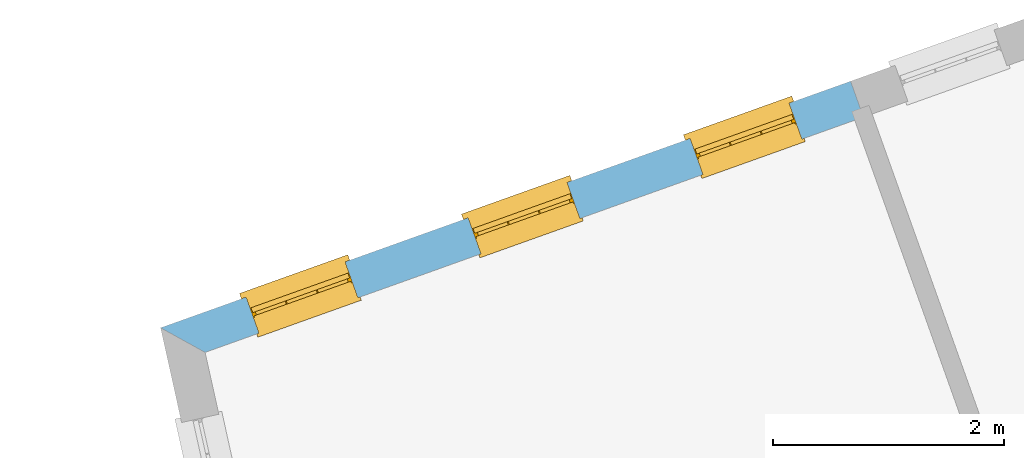
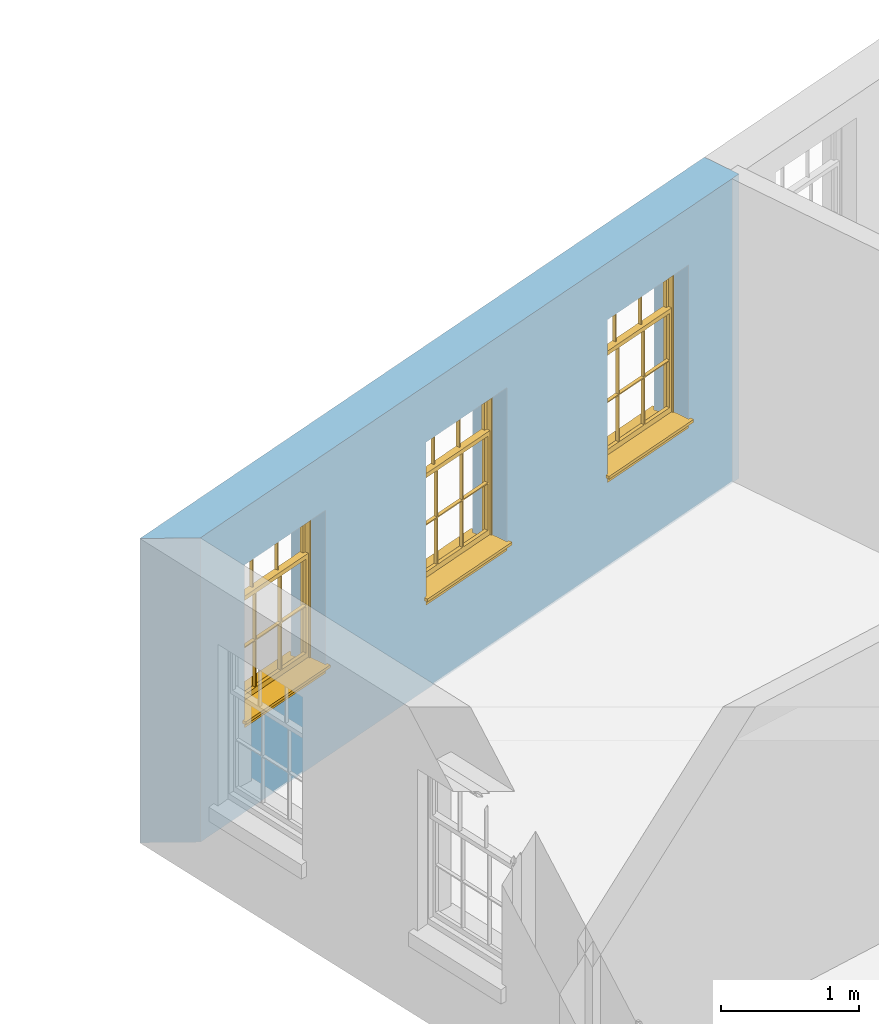
# One storey, part 4 of 11: 3 windows, 3 openings, plus 1 element that does not belong to this part.
"""IFC2X3 building model written with IfcOpenShell, lengths in metres."""

import ifcopenshell
import ifcopenshell.guid

model = None  # the IFC model being written
_history = None  # IfcOwnerHistory: only IFC2X3 demands one
_inside = {}  # id of a spatial element -> (the spatial element, [elements in it])
_under = {}  # id of a project, library or spatial element -> (it, [spatial elements below it])
_declared = {}  # id of a project -> (the project, [libraries it declares])
_typed = {}  # id of a type object -> (the type object, [elements of that type])
_made_of = {}  # id of a material, layer set ... -> (it, [elements and type objects made of it])


def new_model(schema):
    """Start an empty IFC model of exactly this schema.

    Asked for "IFC4X3", IfcOpenShell would pick the latest addendum, in which some entities
    have other attributes; the version numbers below select the first issue.
    IFC2X3 requires an IfcOwnerHistory on every rooted entity: one is made here for all.
    """
    global model, _history
    if schema == "IFC4X3":
        model = ifcopenshell.file(schema_version=(4, 3, 0, 0))
    else:
        model = ifcopenshell.file(schema=schema)
    _inside.clear()
    _under.clear()
    _declared.clear()
    _typed.clear()
    _made_of.clear()
    _history = None
    if model.schema == "IFC2X3":
        org = make("IfcOrganization", Name="unknown")
        user = make(
            "IfcPersonAndOrganization",
            ThePerson=make("IfcPerson", FamilyName="unknown"),
            TheOrganization=org,
        )
        app = make(
            "IfcApplication",
            ApplicationDeveloper=org,
            Version="unknown",
            ApplicationFullName="unknown",
            ApplicationIdentifier="unknown",
        )
        _history = make(
            "IfcOwnerHistory",
            OwningUser=user,
            OwningApplication=app,
            ChangeAction="ADDED",
            CreationDate=0,
        )
    return model


def make(cls, **values):
    """One entity of the class cls with the attributes given. An attribute that is None is left unset."""
    return model.create_entity(
        cls, **{name: value for name, value in values.items() if value is not None}
    )


def rooted(cls, **values):
    """An entity with a GlobalId (a new one), such as an element, a storey or a relation."""
    return make(cls, GlobalId=ifcopenshell.guid.new(), OwnerHistory=_history, **values)


def si_unit(unit_type, name, prefix=None):
    """IfcSIUnit, for example si_unit("LENGTHUNIT", "METRE", prefix="MILLI")."""
    return make("IfcSIUnit", UnitType=unit_type, Prefix=prefix, Name=name)


def assignment(units):
    """IfcUnitAssignment: the units of a project."""
    return None if units is None else make("IfcUnitAssignment", Units=units)


def point(xyz):
    """IfcCartesianPoint."""
    return None if xyz is None else make("IfcCartesianPoint", Coordinates=xyz)


def direction(xyz):
    """IfcDirection."""
    return None if xyz is None else make("IfcDirection", DirectionRatios=xyz)


def frame(location, z_axis=None, x_axis=None):
    """IfcAxis2Placement3D, a coordinate frame: its origin and axes. An axis left out is left unset."""
    return make(
        "IfcAxis2Placement3D",
        Location=point(location),
        Axis=direction(z_axis),
        RefDirection=direction(x_axis),
    )


def origin():
    """The frame at (0, 0, 0) with its axes left unset."""
    return frame((0.0, 0.0, 0.0))


def place(relative_to, where):
    """IfcLocalPlacement: puts the frame where relative to a parent placement (None: the world)."""
    return make(
        "IfcLocalPlacement", PlacementRelTo=relative_to, RelativePlacement=where
    )


def context(
    kind, dimensions, precision=None, world=None, true_north=None, identifier=None
):
    """IfcGeometricRepresentationContext, for example the 3D "Model" context."""
    return make(
        "IfcGeometricRepresentationContext",
        ContextIdentifier=identifier,
        ContextType=kind,
        CoordinateSpaceDimension=dimensions,
        Precision=precision,
        WorldCoordinateSystem=world,
        TrueNorth=true_north,
    )


def subcontext(parent, identifier, kind, view, scale=None):
    """IfcGeometricRepresentationSubContext, for example "Body" below "Model"."""
    return make(
        "IfcGeometricRepresentationSubContext",
        ContextIdentifier=identifier,
        ContextType=kind,
        ParentContext=parent,
        TargetScale=scale,
        TargetView=view,
    )


def project(units=None, contexts=None):
    """IfcProject with its units and contexts."""
    return rooted(
        "IfcProject",
        Name="project",
        RepresentationContexts=contexts,
        UnitsInContext=assignment(units),
    )


def spatial(cls, under=None, at=None, **own):
    """A site, building, storey or space (cls), placed at a placement, below another one or the project."""
    s = rooted(cls, ObjectPlacement=at, **own)
    if under is not None:
        _under.setdefault(under.id(), (under, []))[1].append(s)
    return s


def polyline(points):
    """IfcPolyline through the points."""
    return make("IfcPolyline", Points=[point(p) for p in points])


def outline(outer, holes=None, kind="AREA"):
    """IfcArbitraryClosedProfileDef: a profile drawn as a closed curve; with holes, ...WithVoids."""
    if holes is None:
        return make("IfcArbitraryClosedProfileDef", ProfileType=kind, OuterCurve=outer)
    return make(
        "IfcArbitraryProfileDefWithVoids",
        ProfileType=kind,
        OuterCurve=outer,
        InnerCurves=holes,
    )


def extrude(swept, where, along, depth):
    """IfcExtrudedAreaSolid: the profile swept, set in the frame where, extruded along a direction by depth."""
    return make(
        "IfcExtrudedAreaSolid",
        SweptArea=swept,
        Position=where,
        ExtrudedDirection=direction(along),
        Depth=depth,
    )


def faces_of(points, faces, orient=None, outer=None):
    """IfcFace entities. A face is a list of loops; a loop is a list of indices into points, from 0.

    orient and outer hold one flag for each loop. By default every Orientation is true, the
    first loop of a face is its IfcFaceOuterBound and the others are IfcFaceBound.
    """
    made = []
    for i, loops in enumerate(faces):
        bounds = []
        for j, loop in enumerate(loops):
            is_outer = j == 0 if outer is None else outer[i][j]
            bounds.append(
                make(
                    "IfcFaceOuterBound" if is_outer else "IfcFaceBound",
                    Bound=make("IfcPolyLoop", Polygon=[points[k] for k in loop]),
                    Orientation=True if orient is None else orient[i][j],
                )
            )
        made.append(make("IfcFace", Bounds=bounds))
    return made


def faceted_brep(points, faces, orient=None, outer=None, voids=None):
    """IfcFacetedBrep: a solid bounded by flat faces; with voids (closed shells), ...WithVoids."""
    shared = [point(p) for p in points]
    hull = make("IfcClosedShell", CfsFaces=faces_of(shared, faces, orient, outer))
    if voids is None:
        return make("IfcFacetedBrep", Outer=hull)
    return make(
        "IfcFacetedBrepWithVoids",
        Outer=hull,
        Voids=[
            make(cls, CfsFaces=faces_of(shared, fs, o, b)) for cls, fs, o, b in voids
        ],
    )


def shape(context_of_items, identifier, shape_type, items):
    """IfcShapeRepresentation: the items that make up one representation, for example the "Body"."""
    return make(
        "IfcShapeRepresentation",
        ContextOfItems=context_of_items,
        RepresentationIdentifier=identifier,
        RepresentationType=shape_type,
        Items=items,
    )


def material(Name=None, Category=None):
    """IfcMaterial."""
    return make("IfcMaterial", Name=Name, Category=Category)


def layer(
    of_material, thickness, ventilated=None, Name=None, Category=None, Priority=None
):
    """IfcMaterialLayer: one layer of a wall or slab, of a material (None: an air gap)."""
    return make(
        "IfcMaterialLayer",
        Material=of_material,
        LayerThickness=thickness,
        IsVentilated=ventilated,
        Name=Name,
        Category=Category,
        Priority=Priority,
    )


def layer_set(layers, Name=None):
    """IfcMaterialLayerSet."""
    return make("IfcMaterialLayerSet", MaterialLayers=layers, LayerSetName=Name)


def layer_usage(for_layer_set, set_direction, sense, offset, extent=None):
    """IfcMaterialLayerSetUsage: how a layer set lies in its element."""
    return make(
        "IfcMaterialLayerSetUsage",
        ForLayerSet=for_layer_set,
        LayerSetDirection=set_direction,
        DirectionSense=sense,
        OffsetFromReferenceLine=offset,
        ReferenceExtent=extent,
    )


def made_of(thing, what):
    """Note that an element or type object is made of a material, layer set ...; save() writes the relation."""
    if what is not None:
        _made_of.setdefault(what.id(), (what, []))[1].append(thing)
    return thing


def element(
    cls,
    number,
    at=None,
    inside=None,
    cuts=None,
    type_object=None,
    material=None,
    context=None,
    identifier="Body",
    shape_type=None,
    held_by="IfcProductDefinitionShape",
    body=None,
    shapes=None,
    **own,
):
    """One element of the class cls, such as IfcWall. Its Tag is "e" and its number.

    at: its placement. inside: the storey or other place that contains it. cuts: it is an
    opening in that element (IfcRelVoidsElement). A single representation is given by context,
    identifier, shape_type and body (its items); several are given by shapes. held_by: the class
    of the entity that holds the representations. save() writes the other relations.
    """
    e = rooted(cls, Tag="e%d" % number, ObjectPlacement=at, **own)
    if body is not None:
        shapes = [shape(context, identifier, shape_type, body)]
    if shapes is not None:
        e.Representation = make(held_by, Representations=shapes)
    if inside is not None:
        _inside.setdefault(inside.id(), (inside, []))[1].append(e)
    if cuts is not None:
        rooted(
            "IfcRelVoidsElement", RelatingBuildingElement=cuts, RelatedOpeningElement=e
        )
    if type_object is not None:
        _typed.setdefault(type_object.id(), (type_object, []))[1].append(e)
    return made_of(e, material)


def fill(opening, filler):
    """IfcRelFillsElement: the door or window that sits in an opening."""
    return rooted(
        "IfcRelFillsElement",
        RelatingOpeningElement=opening,
        RelatedBuildingElement=filler,
    )


def aggregate(whole, parts):
    """IfcRelAggregates: a whole, such as a stair, and the parts it consists of."""
    return rooted("IfcRelAggregates", RelatingObject=whole, RelatedObjects=parts)


def save(model, path):
    """Write the relations noted so far, then the file.

    IfcRelAggregates (storeys below a building ...), IfcRelContainedInSpatialStructure (elements
    in a storey), IfcRelDefinesByType, IfcRelAssociatesMaterial and IfcRelDeclares: one each for
    every whole, place, type object, material and project.
    """
    for whole, parts in _under.values():
        aggregate(whole, parts)
    for where, things in _inside.values():
        rooted(
            "IfcRelContainedInSpatialStructure",
            RelatedElements=things,
            RelatingStructure=where,
        )
    for kind, things in _typed.values():
        rooted("IfcRelDefinesByType", RelatedObjects=things, RelatingType=kind)
    for what, things in _made_of.values():
        rooted("IfcRelAssociatesMaterial", RelatedObjects=things, RelatingMaterial=what)
    for by, libraries in _declared.values():
        rooted("IfcRelDeclares", RelatingContext=by, RelatedDefinitions=libraries)
    model.write(path)


model = new_model("IFC2X3")

# Units and contexts
model_context = context("Model", 3, world=origin())
body_context = subcontext(model_context, "Body", "Model", "MODEL_VIEW")
ifc_project = project(units=[si_unit("PLANEANGLEUNIT", "RADIAN"), si_unit("MASSUNIT", "GRAM", prefix="KILO"), si_unit("FORCEUNIT", "NEWTON", prefix="KILO"), si_unit("LENGTHUNIT", "METRE")], contexts=[model_context])

# Site, building, storey
site_placement = place(None, origin())
site = spatial("IfcSite", under=ifc_project, at=site_placement, CompositionType="ELEMENT")
building_placement = place(None, origin())
building = spatial("IfcBuilding", under=site, at=building_placement, Name="Building plot-16", CompositionType="ELEMENT")
storey_placement = place(None, frame((0.0, 0.0, 9.0)))
storey = spatial("IfcBuildingStorey", under=building, at=storey_placement, Name="Floor 2", CompositionType="ELEMENT", Elevation=9.0)

# Wall, openings, windows
ifc_material = material(Name="Masonry")
ifc_layer = layer(ifc_material, 0.33, ventilated=False)
ifc_layer_set = layer_set([ifc_layer], Name="My Wall")
ifc_layer_usage = layer_usage(ifc_layer_set, "AXIS2", "NEGATIVE", 0.08)
wall_placement = place(storey_placement, origin())
wall = element("IfcWallStandardCase", 1, at=wall_placement, inside=storey, material=ifc_layer_usage, Name="exterior", context=body_context, shape_type="SweptSolid", body=[
    extrude(outline(polyline([(92.4003543446355, 39.7153448005522), (92.2893042146699, 40.0260985111248), (86.3199462197779, 37.892904413708), (86.7051504212186, 37.6801216821844), (92.4003543446355, 39.7153448005522)])), origin(), (0.0, 0.0, 1.0), 2.7),
])
opening_1_placement = place(storey_placement, frame((0.0, 0.0, 0.75)))
opening_1 = element("IfcOpeningElement", 2, at=opening_1_placement, cuts=wall, Name="Opening", ObjectType="Opening", context=body_context, shape_type="SweptSolid", body=[
    extrude(outline(polyline([(91.7574900780122, 39.8360508078019), (90.9005631791605, 39.5298216615332), (91.0116133091261, 39.2190679509606), (91.8685402079777, 39.5252970972293), (91.7574900780122, 39.8360508078019)])), origin(), (0.0, 0.0, 1.0), 1.445),
])
opening_2_placement = place(storey_placement, frame((0.0, 0.0, 0.75)))
opening_2 = element("IfcOpeningElement", 3, at=opening_2_placement, cuts=wall, Name="Opening", ObjectType="Opening", context=body_context, shape_type="SweptSolid", body=[
    extrude(outline(polyline([(89.8369349058449, 39.1497262548875), (88.9800080069932, 38.8434971086188), (89.0910581369588, 38.5327433980462), (89.9479850358105, 38.8389725443149), (89.8369349058449, 39.1497262548875)])), origin(), (0.0, 0.0, 1.0), 1.445),
])
opening_3_placement = place(storey_placement, frame((0.0, 0.0, 0.75)))
opening_3 = element("IfcOpeningElement", 4, at=opening_3_placement, cuts=wall, Name="Opening", ObjectType="Opening", context=body_context, shape_type="SweptSolid", body=[
    extrude(outline(polyline([(87.9163797336776, 38.4634017019731), (87.0594528348259, 38.1571725557044), (87.1705029647915, 37.8464188451318), (88.0274298636432, 38.1526479914005), (87.9163797336776, 38.4634017019731)])), origin(), (0.0, 0.0, 1.0), 1.445),
])
window_1_placement = place(storey_placement, frame((91.8416189643497, 39.6006313300954, 0.75), z_axis=(0.0, 0.0, 1.0), x_axis=(-0.856926898851668, -0.306229146268699, 0.0)))
window_1 = element("IfcWindow", 5, at=window_1_placement, inside=storey, Name="living outside window", OverallHeight=1.445, OverallWidth=0.91, context=body_context, shape_type="Brep", held_by="IfcProductRepresentation", body=[
    faceted_brep([(0.876875, -0.105, 0.999097), (0.876875, -0.105, 1.411875), (0.9, -0.105, 1.435), (0.033125, -0.105, 1.411875), (0.033125, -0.105, 0.999097), (0.01, -0.105, 1.435), (0.033125, -0.135, 1.411875), (0.01, -0.135, 1.435), (0.033125, -0.135, 0.999097), (0.876875, -0.135, 1.411875), (0.876875, -0.135, 0.999097), (0.9, -0.135, 1.435), (0.033125, -0.105, 0.960972), (0.01, -0.105, 0.960972), (0.033125, -0.105, 0.548195), (0.876875, -0.105, 0.960972), (0.876875, -0.105, 0.548195), (0.9, -0.105, 0.960972), (0.876875, -0.105, 0.538195), (0.876875, -0.105, 0.125417), (0.9, -0.105, 0.077167), (0.033125, -0.105, 0.125417), (0.033125, -0.105, 0.538195), (0.01, -0.105, 0.077167), (0.9, -0.135, 0.960972), (0.01, -0.135, 0.960972), (-0.0425, -0.25, 0.01), (-0.0425, -0.3, 0.001667), (0.0, -0.25, 0.01), (0.9525, -0.25, 0.01), (0.91, -0.25, 0.01), (0.9525, -0.3, 0.001667), (-0.02, 0.08, 0.077167), (0.0, 0.08, 0.077167), (-0.02, 0.11, 0.077167), (0.0, -0.06, 0.077167), (0.01, -0.06, 0.077167), (0.91, -0.06, 0.077167), (0.91, 0.08, 0.077167), (0.9, -0.06, 0.077167), (0.93, 0.08, 0.077167), (0.93, 0.11, 0.077167), (0.01, -0.105, 0.999097), (0.01, -0.075, 0.999097), (0.9, -0.105, 0.999097), (0.9, -0.075, 0.999097), (0.876875, -0.075, 0.125417), (0.876875, -0.075, 0.538195), (0.9, -0.075, 0.077167), (0.876875, -0.075, 0.548195), (0.876875, -0.075, 0.960972), (0.033125, -0.075, 0.125417), (0.01, -0.075, 0.077167), (0.033125, -0.075, 0.538195), (0.033125, -0.075, 0.960972), (0.033125, -0.075, 0.548195), (-0.02, 0.08, 0.052167), (-0.02, 0.11, 0.052167), (0.93, 0.11, 0.052167), (0.93, 0.08, 0.052167), (0.91, 0.08, 0.052167), (0.0, 0.08, 0.052167), (0.91, -0.15, 0.026667), (0.0, -0.15, 0.026667), (-0.0425, -0.3, -0.123333), (0.9525, -0.3, -0.123333), (-0.0425, -0.25, -0.123333), (0.9525, -0.25, -0.123333), (0.01, -0.06, 1.435), (0.9, -0.06, 1.435), (0.0, -0.06, 1.445), (0.91, -0.06, 1.445), (0.01, -0.15, 0.077167), (0.9, -0.15, 0.077167), (0.592292, -0.105, 0.125417), (0.592292, -0.075, 0.125417), (0.317708, -0.075, 0.125417), (0.317708, -0.105, 0.125417), (0.592292, -0.105, 0.548195), (0.317708, -0.105, 0.548195), (0.317708, -0.105, 0.538195), (0.592292, -0.105, 0.538195), (0.592292, -0.075, 0.548195), (0.317708, -0.075, 0.548195), (0.602292, -0.075, 0.548195), (0.602292, -0.105, 0.548195), (0.317708, -0.075, 0.538195), (0.307708, -0.075, 0.125417), (0.307708, -0.075, 0.538195), (0.602292, -0.075, 0.538195), (0.602292, -0.075, 0.125417), (0.592292, -0.075, 0.538195), (0.307708, -0.075, 0.548195), (0.317708, -0.075, 0.960972), (0.307708, -0.075, 0.960972), (0.602292, -0.075, 0.960972), (0.592292, -0.075, 0.960972), (0.307708, -0.105, 0.538195), (0.307708, -0.105, 0.125417), (0.307708, -0.105, 0.548195), (0.307708, -0.105, 0.960972), (0.592292, -0.105, 0.960972), (0.317708, -0.105, 0.960972), (0.602292, -0.105, 0.960972), (0.602292, -0.105, 0.538195), (0.602292, -0.105, 0.125417), (0.317708, -0.135, 1.411875), (0.307708, -0.135, 1.411875), (0.307708, -0.135, 0.999097), (0.317708, -0.135, 0.999097), (0.602292, -0.135, 1.411875), (0.592292, -0.135, 1.411875), (0.592292, -0.135, 0.999097), (0.602292, -0.135, 0.999097), (0.317708, -0.105, 0.999097), (0.307708, -0.105, 0.999097), (0.307708, -0.105, 1.411875), (0.317708, -0.105, 1.411875), (0.602292, -0.105, 0.999097), (0.592292, -0.105, 0.999097), (0.592292, -0.105, 1.411875), (0.602292, -0.105, 1.411875), (0.91, -0.15, 1.445), (0.9, -0.15, 1.435), (0.01, -0.15, 1.435), (0.0, -0.15, 1.445), (0.91, -0.25, 0.0), (0.0, -0.25, 0.0), (0.91, 0.08, 0.0), (0.0, 0.08, 0.0)], [[[0, 1, 2]], [[3, 4, 5]], [[6, 7, 8]], [[9, 10, 11]], [[12, 13, 14]], [[15, 16, 17]], [[18, 19, 20]], [[21, 22, 23]], [[24, 15, 17]], [[13, 12, 25]], [[26, 27, 28]], [[29, 30, 31]], [[32, 33, 34]], [[35, 36, 33]], [[37, 38, 39]], [[40, 41, 38]], [[42, 4, 43]], [[44, 45, 0]], [[46, 47, 48]], [[49, 50, 45]], [[51, 52, 53]], [[54, 55, 43]], [[38, 33, 36, 39]], [[41, 34, 33, 38]], [[56, 32, 34, 57]], [[57, 34, 41, 58]], [[58, 41, 40, 59]], [[57, 58, 60, 61]], [[52, 48, 39, 36]], [[62, 63, 28, 30]], [[27, 31, 30, 28]], [[27, 64, 65, 31]], [[66, 67, 65, 64]], [[2, 5, 68, 69]], [[68, 70, 71, 69]], [[20, 23, 72, 73]], [[73, 72, 63, 62]], [[74, 75, 76, 77]], [[78, 79, 80, 81]], [[78, 82, 83, 79]], [[16, 49, 84, 85]], [[86, 76, 87, 88]], [[89, 90, 75, 91]], [[92, 88, 53, 55]], [[82, 91, 86, 83]], [[93, 83, 92, 94]], [[95, 84, 82, 96]], [[89, 84, 49, 47]], [[97, 88, 87, 98]], [[22, 53, 88, 97]], [[81, 91, 75, 74]], [[80, 86, 91, 81]], [[77, 76, 86, 80]], [[99, 92, 55, 14]], [[100, 94, 92, 99]], [[101, 96, 82, 78]], [[79, 83, 93, 102]], [[85, 84, 95, 103]], [[104, 89, 47, 18]], [[105, 90, 89, 104]], [[104, 18, 16, 85]], [[80, 97, 98, 77]], [[104, 81, 74, 105]], [[103, 101, 78, 85]], [[99, 14, 22, 97]], [[102, 100, 99, 79]], [[106, 107, 108, 109]], [[110, 111, 112, 113]], [[114, 115, 116, 117]], [[118, 119, 120, 121]], [[107, 116, 115, 108]], [[111, 120, 119, 112]], [[109, 114, 117, 106]], [[113, 118, 121, 110]], [[85, 78, 81, 104]], [[84, 89, 91, 82]], [[83, 86, 88, 92]], [[79, 99, 97, 80]], [[109, 112, 119, 114]], [[102, 93, 96, 101]], [[106, 117, 120, 111]], [[98, 87, 51, 21]], [[6, 3, 116, 107]], [[110, 121, 1, 9]], [[19, 46, 90, 105]], [[26, 66, 64, 27]], [[29, 31, 65, 67]], [[25, 24, 112, 109]], [[11, 7, 106, 111]], [[75, 48, 52, 76]], [[43, 45, 96, 93]], [[45, 43, 114, 119]], [[5, 2, 120, 117]], [[24, 25, 102, 101]], [[42, 5, 4]], [[2, 44, 0]], [[49, 45, 48, 47]], [[52, 43, 55, 53]], [[14, 13, 23, 22]], [[20, 17, 16, 18]], [[24, 11, 10]], [[25, 8, 7]], [[8, 4, 3, 6]], [[9, 1, 0, 10]], [[15, 50, 49, 16]], [[18, 47, 46, 19]], [[21, 51, 53, 22]], [[14, 55, 54, 12]], [[44, 2, 69, 45]], [[68, 5, 42, 43]], [[36, 35, 70, 68]], [[39, 69, 71, 37]], [[62, 122, 123, 73]], [[63, 72, 124, 125]], [[8, 108, 115, 4]], [[113, 10, 0, 118]], [[94, 100, 12, 54]], [[17, 20, 73, 24]], [[72, 23, 13, 25]], [[52, 36, 68, 43]], [[69, 39, 48, 45]], [[11, 24, 73, 123]], [[7, 124, 72, 25]], [[23, 77, 98]], [[98, 21, 23]], [[105, 74, 20]], [[20, 19, 105]], [[20, 74, 77, 23]], [[113, 112, 24]], [[24, 10, 113]], [[25, 109, 108]], [[108, 8, 25]], [[110, 9, 11]], [[11, 111, 110]], [[7, 6, 107]], [[107, 106, 7]], [[5, 117, 116]], [[116, 3, 5]], [[121, 120, 2]], [[2, 1, 121]], [[11, 123, 124, 7]], [[122, 125, 124, 123]], [[43, 93, 94]], [[94, 54, 43]], [[96, 45, 95]], [[50, 95, 45]], [[15, 103, 95, 50]], [[48, 75, 90]], [[90, 46, 48]], [[87, 76, 52]], [[52, 51, 87]], [[103, 15, 24]], [[24, 101, 103]], [[100, 102, 25]], [[25, 12, 100]], [[115, 114, 43]], [[43, 4, 115]], [[118, 0, 45]], [[45, 119, 118]], [[71, 70, 125, 122]], [[70, 35, 63, 125]], [[122, 62, 37, 71]], [[126, 67, 66, 127]], [[60, 58, 59]], [[38, 60, 59, 40]], [[61, 56, 57]], [[32, 56, 61, 33]], [[61, 60, 128, 129]], [[62, 60, 38, 37]], [[126, 128, 60, 62]], [[33, 61, 63, 35]], [[61, 129, 127, 63]], [[128, 126, 127, 129]], [[28, 127, 66, 26]], [[63, 127, 28]], [[29, 67, 126, 30]], [[30, 126, 62]]]),
])
fill(opening_1, window_1)
window_2_placement = place(storey_placement, frame((89.9210637921824, 38.914306777181, 0.75), z_axis=(0.0, 0.0, 1.0), x_axis=(-0.856926898851668, -0.306229146268706, 0.0)))
window_2 = element("IfcWindow", 6, at=window_2_placement, inside=storey, Name="living outside window", OverallHeight=1.445, OverallWidth=0.91, context=body_context, shape_type="Brep", held_by="IfcProductRepresentation", body=[
    faceted_brep([(0.876875, -0.105, 0.999097), (0.876875, -0.105, 1.411875), (0.9, -0.105, 1.435), (0.033125, -0.105, 1.411875), (0.033125, -0.105, 0.999097), (0.01, -0.105, 1.435), (0.033125, -0.135, 1.411875), (0.01, -0.135, 1.435), (0.033125, -0.135, 0.999097), (0.876875, -0.135, 1.411875), (0.876875, -0.135, 0.999097), (0.9, -0.135, 1.435), (0.033125, -0.105, 0.960972), (0.01, -0.105, 0.960972), (0.033125, -0.105, 0.548195), (0.876875, -0.105, 0.960972), (0.876875, -0.105, 0.548195), (0.9, -0.105, 0.960972), (0.876875, -0.105, 0.538195), (0.876875, -0.105, 0.125417), (0.9, -0.105, 0.077167), (0.033125, -0.105, 0.125417), (0.033125, -0.105, 0.538195), (0.01, -0.105, 0.077167), (0.9, -0.135, 0.960972), (0.01, -0.135, 0.960972), (-0.0425, -0.25, 0.01), (-0.0425, -0.3, 0.001667), (0.0, -0.25, 0.01), (0.9525, -0.25, 0.01), (0.91, -0.25, 0.01), (0.9525, -0.3, 0.001667), (-0.02, 0.08, 0.077167), (0.0, 0.08, 0.077167), (-0.02, 0.11, 0.077167), (0.0, -0.06, 0.077167), (0.01, -0.06, 0.077167), (0.91, -0.06, 0.077167), (0.91, 0.08, 0.077167), (0.9, -0.06, 0.077167), (0.93, 0.08, 0.077167), (0.93, 0.11, 0.077167), (0.01, -0.105, 0.999097), (0.01, -0.075, 0.999097), (0.9, -0.105, 0.999097), (0.9, -0.075, 0.999097), (0.876875, -0.075, 0.125417), (0.876875, -0.075, 0.538195), (0.9, -0.075, 0.077167), (0.876875, -0.075, 0.548195), (0.876875, -0.075, 0.960972), (0.033125, -0.075, 0.125417), (0.01, -0.075, 0.077167), (0.033125, -0.075, 0.538195), (0.033125, -0.075, 0.960972), (0.033125, -0.075, 0.548195), (-0.02, 0.08, 0.052167), (-0.02, 0.11, 0.052167), (0.93, 0.11, 0.052167), (0.93, 0.08, 0.052167), (0.91, 0.08, 0.052167), (0.0, 0.08, 0.052167), (0.91, -0.15, 0.026667), (0.0, -0.15, 0.026667), (-0.0425, -0.3, -0.123333), (0.9525, -0.3, -0.123333), (-0.0425, -0.25, -0.123333), (0.9525, -0.25, -0.123333), (0.01, -0.06, 1.435), (0.9, -0.06, 1.435), (0.0, -0.06, 1.445), (0.91, -0.06, 1.445), (0.01, -0.15, 0.077167), (0.9, -0.15, 0.077167), (0.592292, -0.105, 0.125417), (0.592292, -0.075, 0.125417), (0.317708, -0.075, 0.125417), (0.317708, -0.105, 0.125417), (0.592292, -0.105, 0.548195), (0.317708, -0.105, 0.548195), (0.317708, -0.105, 0.538195), (0.592292, -0.105, 0.538195), (0.592292, -0.075, 0.548195), (0.317708, -0.075, 0.548195), (0.602292, -0.075, 0.548195), (0.602292, -0.105, 0.548195), (0.317708, -0.075, 0.538195), (0.307708, -0.075, 0.125417), (0.307708, -0.075, 0.538195), (0.602292, -0.075, 0.538195), (0.602292, -0.075, 0.125417), (0.592292, -0.075, 0.538195), (0.307708, -0.075, 0.548195), (0.317708, -0.075, 0.960972), (0.307708, -0.075, 0.960972), (0.602292, -0.075, 0.960972), (0.592292, -0.075, 0.960972), (0.307708, -0.105, 0.538195), (0.307708, -0.105, 0.125417), (0.307708, -0.105, 0.548195), (0.307708, -0.105, 0.960972), (0.592292, -0.105, 0.960972), (0.317708, -0.105, 0.960972), (0.602292, -0.105, 0.960972), (0.602292, -0.105, 0.538195), (0.602292, -0.105, 0.125417), (0.317708, -0.135, 1.411875), (0.307708, -0.135, 1.411875), (0.307708, -0.135, 0.999097), (0.317708, -0.135, 0.999097), (0.602292, -0.135, 1.411875), (0.592292, -0.135, 1.411875), (0.592292, -0.135, 0.999097), (0.602292, -0.135, 0.999097), (0.317708, -0.105, 0.999097), (0.307708, -0.105, 0.999097), (0.307708, -0.105, 1.411875), (0.317708, -0.105, 1.411875), (0.602292, -0.105, 0.999097), (0.592292, -0.105, 0.999097), (0.592292, -0.105, 1.411875), (0.602292, -0.105, 1.411875), (0.91, -0.15, 1.445), (0.9, -0.15, 1.435), (0.01, -0.15, 1.435), (0.0, -0.15, 1.445), (0.91, -0.25, 0.0), (0.0, -0.25, 0.0), (0.91, 0.08, 0.0), (0.0, 0.08, 0.0)], [[[0, 1, 2]], [[3, 4, 5]], [[6, 7, 8]], [[9, 10, 11]], [[12, 13, 14]], [[15, 16, 17]], [[18, 19, 20]], [[21, 22, 23]], [[24, 15, 17]], [[13, 12, 25]], [[26, 27, 28]], [[29, 30, 31]], [[32, 33, 34]], [[35, 36, 33]], [[37, 38, 39]], [[40, 41, 38]], [[42, 4, 43]], [[44, 45, 0]], [[46, 47, 48]], [[49, 50, 45]], [[51, 52, 53]], [[54, 55, 43]], [[38, 33, 36, 39]], [[41, 34, 33, 38]], [[56, 32, 34, 57]], [[57, 34, 41, 58]], [[58, 41, 40, 59]], [[57, 58, 60, 61]], [[52, 48, 39, 36]], [[62, 63, 28, 30]], [[27, 31, 30, 28]], [[27, 64, 65, 31]], [[66, 67, 65, 64]], [[2, 5, 68, 69]], [[68, 70, 71, 69]], [[20, 23, 72, 73]], [[73, 72, 63, 62]], [[74, 75, 76, 77]], [[78, 79, 80, 81]], [[78, 82, 83, 79]], [[16, 49, 84, 85]], [[86, 76, 87, 88]], [[89, 90, 75, 91]], [[92, 88, 53, 55]], [[82, 91, 86, 83]], [[93, 83, 92, 94]], [[95, 84, 82, 96]], [[89, 84, 49, 47]], [[97, 88, 87, 98]], [[22, 53, 88, 97]], [[81, 91, 75, 74]], [[80, 86, 91, 81]], [[77, 76, 86, 80]], [[99, 92, 55, 14]], [[100, 94, 92, 99]], [[101, 96, 82, 78]], [[79, 83, 93, 102]], [[85, 84, 95, 103]], [[104, 89, 47, 18]], [[105, 90, 89, 104]], [[104, 18, 16, 85]], [[80, 97, 98, 77]], [[104, 81, 74, 105]], [[103, 101, 78, 85]], [[99, 14, 22, 97]], [[102, 100, 99, 79]], [[106, 107, 108, 109]], [[110, 111, 112, 113]], [[114, 115, 116, 117]], [[118, 119, 120, 121]], [[107, 116, 115, 108]], [[111, 120, 119, 112]], [[109, 114, 117, 106]], [[113, 118, 121, 110]], [[85, 78, 81, 104]], [[84, 89, 91, 82]], [[83, 86, 88, 92]], [[79, 99, 97, 80]], [[109, 112, 119, 114]], [[102, 93, 96, 101]], [[106, 117, 120, 111]], [[98, 87, 51, 21]], [[6, 3, 116, 107]], [[110, 121, 1, 9]], [[19, 46, 90, 105]], [[26, 66, 64, 27]], [[29, 31, 65, 67]], [[25, 24, 112, 109]], [[11, 7, 106, 111]], [[75, 48, 52, 76]], [[43, 45, 96, 93]], [[45, 43, 114, 119]], [[5, 2, 120, 117]], [[24, 25, 102, 101]], [[42, 5, 4]], [[2, 44, 0]], [[49, 45, 48, 47]], [[52, 43, 55, 53]], [[14, 13, 23, 22]], [[20, 17, 16, 18]], [[24, 11, 10]], [[25, 8, 7]], [[8, 4, 3, 6]], [[9, 1, 0, 10]], [[15, 50, 49, 16]], [[18, 47, 46, 19]], [[21, 51, 53, 22]], [[14, 55, 54, 12]], [[44, 2, 69, 45]], [[68, 5, 42, 43]], [[36, 35, 70, 68]], [[39, 69, 71, 37]], [[62, 122, 123, 73]], [[63, 72, 124, 125]], [[8, 108, 115, 4]], [[113, 10, 0, 118]], [[94, 100, 12, 54]], [[17, 20, 73, 24]], [[72, 23, 13, 25]], [[52, 36, 68, 43]], [[69, 39, 48, 45]], [[11, 24, 73, 123]], [[7, 124, 72, 25]], [[23, 77, 98]], [[98, 21, 23]], [[105, 74, 20]], [[20, 19, 105]], [[20, 74, 77, 23]], [[113, 112, 24]], [[24, 10, 113]], [[25, 109, 108]], [[108, 8, 25]], [[110, 9, 11]], [[11, 111, 110]], [[7, 6, 107]], [[107, 106, 7]], [[5, 117, 116]], [[116, 3, 5]], [[121, 120, 2]], [[2, 1, 121]], [[11, 123, 124, 7]], [[122, 125, 124, 123]], [[43, 93, 94]], [[94, 54, 43]], [[96, 45, 95]], [[50, 95, 45]], [[15, 103, 95, 50]], [[48, 75, 90]], [[90, 46, 48]], [[87, 76, 52]], [[52, 51, 87]], [[103, 15, 24]], [[24, 101, 103]], [[100, 102, 25]], [[25, 12, 100]], [[115, 114, 43]], [[43, 4, 115]], [[118, 0, 45]], [[45, 119, 118]], [[71, 70, 125, 122]], [[70, 35, 63, 125]], [[122, 62, 37, 71]], [[126, 67, 66, 127]], [[60, 58, 59]], [[38, 60, 59, 40]], [[61, 56, 57]], [[32, 56, 61, 33]], [[61, 60, 128, 129]], [[62, 60, 38, 37]], [[126, 128, 60, 62]], [[33, 61, 63, 35]], [[61, 129, 127, 63]], [[128, 126, 127, 129]], [[28, 127, 66, 26]], [[63, 127, 28]], [[29, 67, 126, 30]], [[30, 126, 62]]]),
])
fill(opening_2, window_2)
window_3_placement = place(storey_placement, frame((88.0005086200152, 38.2279822242666, 0.75), z_axis=(0.0, 0.0, 1.0), x_axis=(-0.856926898851668, -0.306229146268706, 0.0)))
window_3 = element("IfcWindow", 7, at=window_3_placement, inside=storey, Name="living outside window", OverallHeight=1.445, OverallWidth=0.91, context=body_context, shape_type="Brep", held_by="IfcProductRepresentation", body=[
    faceted_brep([(0.876875, -0.105, 0.999097), (0.876875, -0.105, 1.411875), (0.9, -0.105, 1.435), (0.033125, -0.105, 1.411875), (0.033125, -0.105, 0.999097), (0.01, -0.105, 1.435), (0.033125, -0.135, 1.411875), (0.01, -0.135, 1.435), (0.033125, -0.135, 0.999097), (0.876875, -0.135, 1.411875), (0.876875, -0.135, 0.999097), (0.9, -0.135, 1.435), (0.033125, -0.105, 0.960972), (0.01, -0.105, 0.960972), (0.033125, -0.105, 0.548195), (0.876875, -0.105, 0.960972), (0.876875, -0.105, 0.548195), (0.9, -0.105, 0.960972), (0.876875, -0.105, 0.538195), (0.876875, -0.105, 0.125417), (0.9, -0.105, 0.077167), (0.033125, -0.105, 0.125417), (0.033125, -0.105, 0.538195), (0.01, -0.105, 0.077167), (0.9, -0.135, 0.960972), (0.01, -0.135, 0.960972), (-0.0425, -0.25, 0.01), (-0.0425, -0.3, 0.001667), (0.0, -0.25, 0.01), (0.9525, -0.25, 0.01), (0.91, -0.25, 0.01), (0.9525, -0.3, 0.001667), (-0.02, 0.08, 0.077167), (0.0, 0.08, 0.077167), (-0.02, 0.11, 0.077167), (0.0, -0.06, 0.077167), (0.01, -0.06, 0.077167), (0.91, -0.06, 0.077167), (0.91, 0.08, 0.077167), (0.9, -0.06, 0.077167), (0.93, 0.08, 0.077167), (0.93, 0.11, 0.077167), (0.01, -0.105, 0.999097), (0.01, -0.075, 0.999097), (0.9, -0.105, 0.999097), (0.9, -0.075, 0.999097), (0.876875, -0.075, 0.125417), (0.876875, -0.075, 0.538195), (0.9, -0.075, 0.077167), (0.876875, -0.075, 0.548195), (0.876875, -0.075, 0.960972), (0.033125, -0.075, 0.125417), (0.01, -0.075, 0.077167), (0.033125, -0.075, 0.538195), (0.033125, -0.075, 0.960972), (0.033125, -0.075, 0.548195), (-0.02, 0.08, 0.052167), (-0.02, 0.11, 0.052167), (0.93, 0.11, 0.052167), (0.93, 0.08, 0.052167), (0.91, 0.08, 0.052167), (0.0, 0.08, 0.052167), (0.91, -0.15, 0.026667), (0.0, -0.15, 0.026667), (-0.0425, -0.3, -0.123333), (0.9525, -0.3, -0.123333), (-0.0425, -0.25, -0.123333), (0.9525, -0.25, -0.123333), (0.01, -0.06, 1.435), (0.9, -0.06, 1.435), (0.0, -0.06, 1.445), (0.91, -0.06, 1.445), (0.01, -0.15, 0.077167), (0.9, -0.15, 0.077167), (0.592292, -0.105, 0.125417), (0.592292, -0.075, 0.125417), (0.317708, -0.075, 0.125417), (0.317708, -0.105, 0.125417), (0.592292, -0.105, 0.548195), (0.317708, -0.105, 0.548195), (0.317708, -0.105, 0.538195), (0.592292, -0.105, 0.538195), (0.592292, -0.075, 0.548195), (0.317708, -0.075, 0.548195), (0.602292, -0.075, 0.548195), (0.602292, -0.105, 0.548195), (0.317708, -0.075, 0.538195), (0.307708, -0.075, 0.125417), (0.307708, -0.075, 0.538195), (0.602292, -0.075, 0.538195), (0.602292, -0.075, 0.125417), (0.592292, -0.075, 0.538195), (0.307708, -0.075, 0.548195), (0.317708, -0.075, 0.960972), (0.307708, -0.075, 0.960972), (0.602292, -0.075, 0.960972), (0.592292, -0.075, 0.960972), (0.307708, -0.105, 0.538195), (0.307708, -0.105, 0.125417), (0.307708, -0.105, 0.548195), (0.307708, -0.105, 0.960972), (0.592292, -0.105, 0.960972), (0.317708, -0.105, 0.960972), (0.602292, -0.105, 0.960972), (0.602292, -0.105, 0.538195), (0.602292, -0.105, 0.125417), (0.317708, -0.135, 1.411875), (0.307708, -0.135, 1.411875), (0.307708, -0.135, 0.999097), (0.317708, -0.135, 0.999097), (0.602292, -0.135, 1.411875), (0.592292, -0.135, 1.411875), (0.592292, -0.135, 0.999097), (0.602292, -0.135, 0.999097), (0.317708, -0.105, 0.999097), (0.307708, -0.105, 0.999097), (0.307708, -0.105, 1.411875), (0.317708, -0.105, 1.411875), (0.602292, -0.105, 0.999097), (0.592292, -0.105, 0.999097), (0.592292, -0.105, 1.411875), (0.602292, -0.105, 1.411875), (0.91, -0.15, 1.445), (0.9, -0.15, 1.435), (0.01, -0.15, 1.435), (0.0, -0.15, 1.445), (0.91, -0.25, 0.0), (0.0, -0.25, 0.0), (0.91, 0.08, 0.0), (0.0, 0.08, 0.0)], [[[0, 1, 2]], [[3, 4, 5]], [[6, 7, 8]], [[9, 10, 11]], [[12, 13, 14]], [[15, 16, 17]], [[18, 19, 20]], [[21, 22, 23]], [[24, 15, 17]], [[13, 12, 25]], [[26, 27, 28]], [[29, 30, 31]], [[32, 33, 34]], [[35, 36, 33]], [[37, 38, 39]], [[40, 41, 38]], [[42, 4, 43]], [[44, 45, 0]], [[46, 47, 48]], [[49, 50, 45]], [[51, 52, 53]], [[54, 55, 43]], [[38, 33, 36, 39]], [[41, 34, 33, 38]], [[56, 32, 34, 57]], [[57, 34, 41, 58]], [[58, 41, 40, 59]], [[57, 58, 60, 61]], [[52, 48, 39, 36]], [[62, 63, 28, 30]], [[27, 31, 30, 28]], [[27, 64, 65, 31]], [[66, 67, 65, 64]], [[2, 5, 68, 69]], [[68, 70, 71, 69]], [[20, 23, 72, 73]], [[73, 72, 63, 62]], [[74, 75, 76, 77]], [[78, 79, 80, 81]], [[78, 82, 83, 79]], [[16, 49, 84, 85]], [[86, 76, 87, 88]], [[89, 90, 75, 91]], [[92, 88, 53, 55]], [[82, 91, 86, 83]], [[93, 83, 92, 94]], [[95, 84, 82, 96]], [[89, 84, 49, 47]], [[97, 88, 87, 98]], [[22, 53, 88, 97]], [[81, 91, 75, 74]], [[80, 86, 91, 81]], [[77, 76, 86, 80]], [[99, 92, 55, 14]], [[100, 94, 92, 99]], [[101, 96, 82, 78]], [[79, 83, 93, 102]], [[85, 84, 95, 103]], [[104, 89, 47, 18]], [[105, 90, 89, 104]], [[104, 18, 16, 85]], [[80, 97, 98, 77]], [[104, 81, 74, 105]], [[103, 101, 78, 85]], [[99, 14, 22, 97]], [[102, 100, 99, 79]], [[106, 107, 108, 109]], [[110, 111, 112, 113]], [[114, 115, 116, 117]], [[118, 119, 120, 121]], [[107, 116, 115, 108]], [[111, 120, 119, 112]], [[109, 114, 117, 106]], [[113, 118, 121, 110]], [[85, 78, 81, 104]], [[84, 89, 91, 82]], [[83, 86, 88, 92]], [[79, 99, 97, 80]], [[109, 112, 119, 114]], [[102, 93, 96, 101]], [[106, 117, 120, 111]], [[98, 87, 51, 21]], [[6, 3, 116, 107]], [[110, 121, 1, 9]], [[19, 46, 90, 105]], [[26, 66, 64, 27]], [[29, 31, 65, 67]], [[25, 24, 112, 109]], [[11, 7, 106, 111]], [[75, 48, 52, 76]], [[43, 45, 96, 93]], [[45, 43, 114, 119]], [[5, 2, 120, 117]], [[24, 25, 102, 101]], [[42, 5, 4]], [[2, 44, 0]], [[49, 45, 48, 47]], [[52, 43, 55, 53]], [[14, 13, 23, 22]], [[20, 17, 16, 18]], [[24, 11, 10]], [[25, 8, 7]], [[8, 4, 3, 6]], [[9, 1, 0, 10]], [[15, 50, 49, 16]], [[18, 47, 46, 19]], [[21, 51, 53, 22]], [[14, 55, 54, 12]], [[44, 2, 69, 45]], [[68, 5, 42, 43]], [[36, 35, 70, 68]], [[39, 69, 71, 37]], [[62, 122, 123, 73]], [[63, 72, 124, 125]], [[8, 108, 115, 4]], [[113, 10, 0, 118]], [[94, 100, 12, 54]], [[17, 20, 73, 24]], [[72, 23, 13, 25]], [[52, 36, 68, 43]], [[69, 39, 48, 45]], [[11, 24, 73, 123]], [[7, 124, 72, 25]], [[23, 77, 98]], [[98, 21, 23]], [[105, 74, 20]], [[20, 19, 105]], [[20, 74, 77, 23]], [[113, 112, 24]], [[24, 10, 113]], [[25, 109, 108]], [[108, 8, 25]], [[110, 9, 11]], [[11, 111, 110]], [[7, 6, 107]], [[107, 106, 7]], [[5, 117, 116]], [[116, 3, 5]], [[121, 120, 2]], [[2, 1, 121]], [[11, 123, 124, 7]], [[122, 125, 124, 123]], [[43, 93, 94]], [[94, 54, 43]], [[96, 45, 95]], [[50, 95, 45]], [[15, 103, 95, 50]], [[48, 75, 90]], [[90, 46, 48]], [[87, 76, 52]], [[52, 51, 87]], [[103, 15, 24]], [[24, 101, 103]], [[100, 102, 25]], [[25, 12, 100]], [[115, 114, 43]], [[43, 4, 115]], [[118, 0, 45]], [[45, 119, 118]], [[71, 70, 125, 122]], [[70, 35, 63, 125]], [[122, 62, 37, 71]], [[126, 67, 66, 127]], [[60, 58, 59]], [[38, 60, 59, 40]], [[61, 56, 57]], [[32, 56, 61, 33]], [[61, 60, 128, 129]], [[62, 60, 38, 37]], [[126, 128, 60, 62]], [[33, 61, 63, 35]], [[61, 129, 127, 63]], [[128, 126, 127, 129]], [[28, 127, 66, 26]], [[63, 127, 28]], [[29, 67, 126, 30]], [[30, 126, 62]]]),
])
fill(opening_3, window_3)

save(model, "model.ifc")
